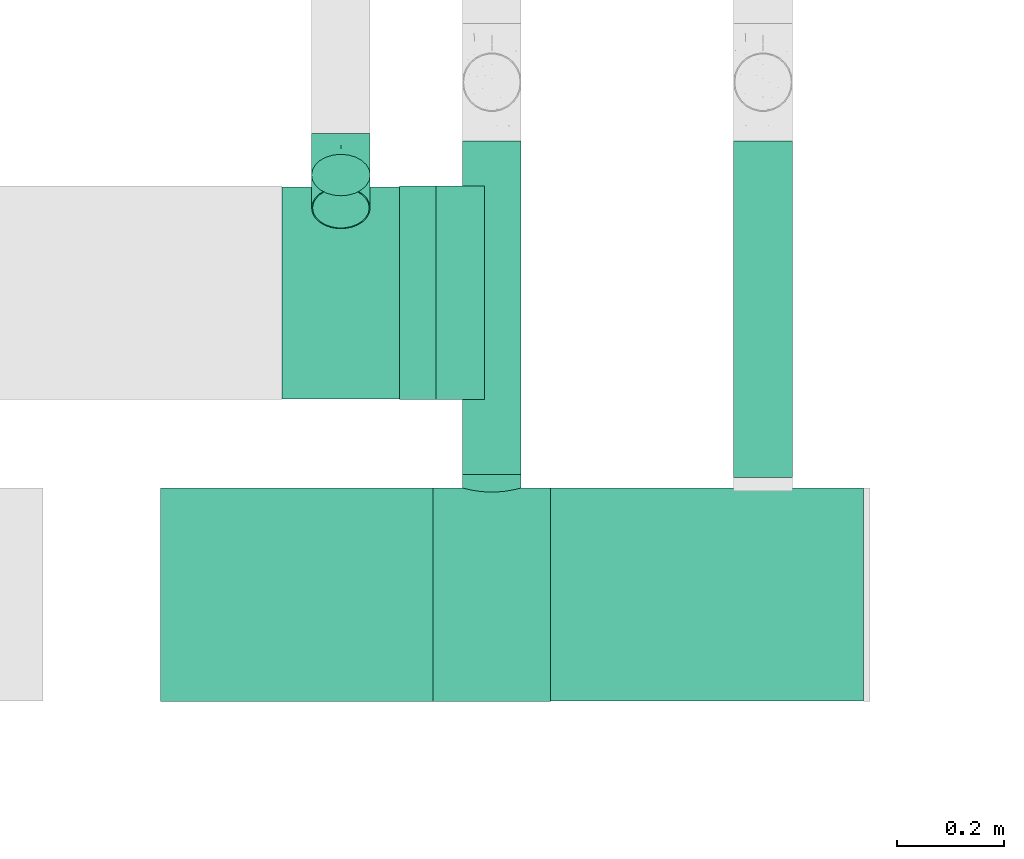
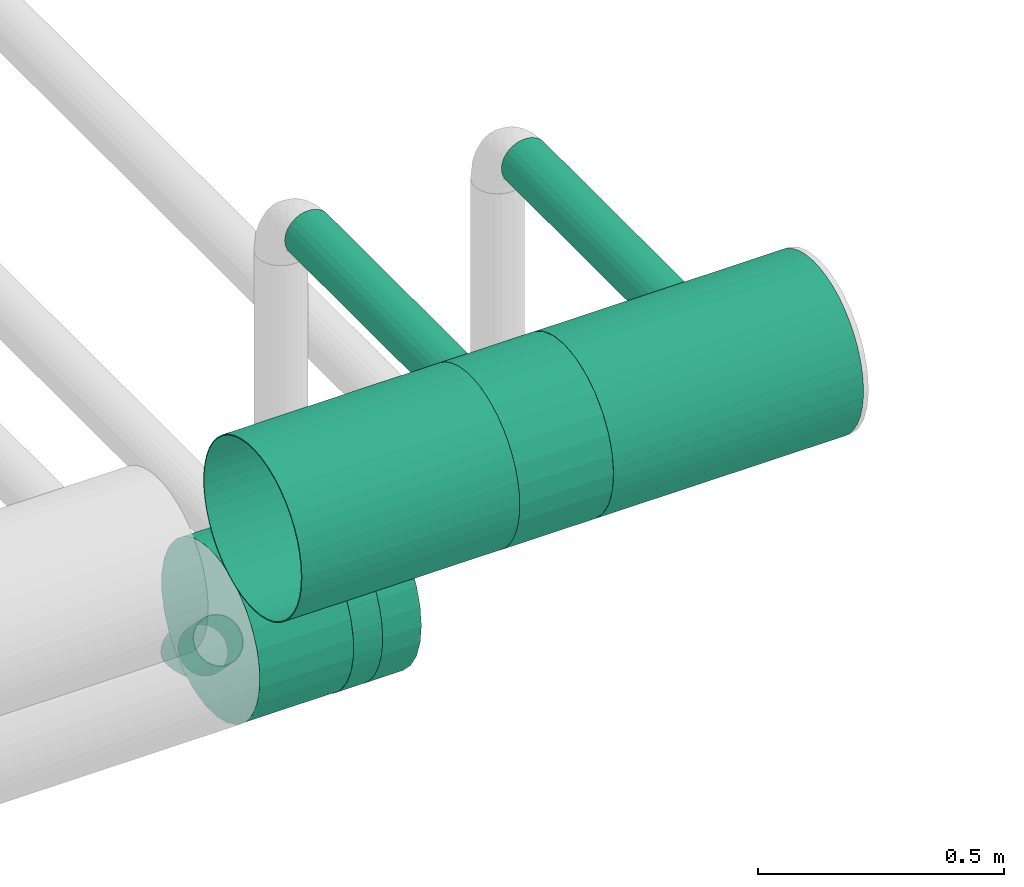
# One storey, part 71 of 91: 6 flow segments, 4 flow fittings.
"""IFC2X3 building model written with IfcOpenShell, lengths in millimetres."""

from ifc_helpers import new_model, entity, si_unit, converted_unit, derived_unit, direction, frame, origin_with_axes, origin_2d_with_axis, place, context, subcontext, project, spatial, hollow_circle, extrude, open_shell, surface_model, source, transform, mapped, material, layer, layer_set, layer_usage, type_object, element, save


model = new_model("IFC2X3")

# Units and contexts
model_context = context("Model", 3, precision=1e-05, world=origin_with_axes(), true_north=direction((0.0, 1.0)))
body_context = subcontext(model_context, "Body", "Model", "MODEL_VIEW")
ifc_project = project(units=[si_unit("AREAUNIT", "SQUARE_METRE"), si_unit("VOLUMEUNIT", "CUBIC_METRE", prefix="DECI"), si_unit("TIMEUNIT", "SECOND"), si_unit("THERMODYNAMICTEMPERATUREUNIT", "DEGREE_CELSIUS"), si_unit("PRESSUREUNIT", "PASCAL"), si_unit("MASSUNIT", "GRAM", prefix="KILO"), si_unit("LENGTHUNIT", "METRE", prefix="MILLI"), si_unit("POWERUNIT", "WATT"), si_unit("ELECTRICCURRENTUNIT", "AMPERE"), si_unit("ELECTRICVOLTAGEUNIT", "VOLT"), derived_unit("VOLUMETRICFLOWRATEUNIT", [(si_unit("VOLUMEUNIT", "CUBIC_METRE", prefix="DECI"), 1), (si_unit("TIMEUNIT", "SECOND"), -1)]), derived_unit("LINEARVELOCITYUNIT", [(si_unit("LENGTHUNIT", "METRE"), 1), (si_unit("TIMEUNIT", "SECOND"), -1)]), derived_unit("MASSDENSITYUNIT", [(si_unit("MASSUNIT", "GRAM", prefix="KILO"), 1), (si_unit("VOLUMEUNIT", "CUBIC_METRE"), -1)]), converted_unit("PLANEANGLEUNIT", "DEGREE", entity("IfcRatioMeasure", 0.01745), si_unit("PLANEANGLEUNIT", "RADIAN"), dimensions=[0, 0, 0, 0, 0, 0, 0])], contexts=[model_context])

# Site, building, storey
site_placement = place(None, origin_with_axes())
site = spatial("IfcSite", under=ifc_project, at=site_placement, CompositionType="ELEMENT")
building_placement = place(site_placement, origin_with_axes())
building = spatial("IfcBuilding", under=site, at=building_placement, Name="mc-building", CompositionType="ELEMENT")
storey_placement = place(building_placement, frame((0.0, 0.0, 8700.0), z_axis=(0.0, 0.0, 1.0), x_axis=(1.0, 0.0, 0.0)))
storey = spatial("IfcBuildingStorey", under=building, at=storey_placement, CompositionType="ELEMENT", Elevation=8700.0)

# Flow fittings
duct_fitting_type_1 = type_object("IfcDuctFittingType", PredefinedType="JUNCTION")
shared_shape_1 = source(origin_with_axes(), body_context, "Body", "SurfaceModel", [
    surface_model("IfcShellBasedSurfaceModel", [(0.0, -225.0, -55.0), (14.23505, -225.0, -53.12592), (-14.23505, -225.0, -53.12592), (-53.12592, -225.0, 14.23505), (-27.5, -225.0, -47.63139), (-47.63139, -225.0, -27.5), (-38.89087, -225.0, -38.89087), (55.0, -225.0, 0.0), (53.12592, -225.0, 14.23505), (38.89087, -225.0, -38.89087), (27.5, -225.0, -47.63139), (53.12592, -225.0, -14.23505), (47.63139, -225.0, -27.5), (-53.12592, -225.0, -14.23505), (-47.63139, -225.0, 27.5), (-38.89087, -225.0, 38.89087), (14.23505, -225.0, 53.12592), (-27.5, -225.0, 47.63139), (-14.23505, -225.0, 53.12592), (47.63139, -225.0, 27.5), (38.89087, -225.0, 38.89087), (27.5, -225.0, 47.63139), (0.0, -225.0, 55.0), (-55.0, -225.0, 0.0), (0.0, -192.28884, 55.0), (-12.29394, -192.68144, 53.60839), (-23.92751, -193.77184, 49.52246), (-34.31923, -195.32745, 42.97895), (-42.9874, -197.03532, 34.30865), (-49.52973, -198.56533, 23.91246), (-53.61252, -199.6229, 12.27592), (-55.0, -200.0, 0.0), (-49.52091, -198.56313, -23.93071), (-42.97449, -197.0325, -34.32482), (-53.60826, -199.62175, -12.29447), (-34.30293, -195.32458, -42.99196), (-23.90904, -193.76957, -49.53138), (-12.27509, -192.68024, -53.61271), (0.0, -192.28884, -55.0), (12.29394, -192.68144, -53.60839), (23.92751, -193.77184, -49.52246), (34.31923, -195.32745, -42.97895), (42.9874, -197.03532, -34.30865), (49.52973, -198.56533, -23.91246), (53.61252, -199.6229, -12.27592), (55.0, -200.0, 0.0), (49.52973, -198.56533, 23.91246), (42.9874, -197.03532, 34.30865), (53.61252, -199.6229, 12.27592), (34.31923, -195.32745, 42.97895), (23.92751, -193.77184, 49.52246), (12.29394, -192.68144, 53.60839), (-110.0, 0.0, -200.0), (-110.0, -44.50419, -194.98559), (-110.0, 44.50419, -194.98559), (-110.0, 194.98559, 44.50419), (-110.0, 86.77674, -180.19378), (-110.0, 180.19378, -86.77674), (-110.0, 156.36629, -124.69796), (-110.0, 124.69796, -156.36629), (-110.0, -200.0, 0.0), (-110.0, -194.98559, 44.50419), (-110.0, -124.69796, -156.36629), (-110.0, -86.77674, -180.19378), (-110.0, -156.36629, -124.69796), (-110.0, -180.19378, -86.77674), (-110.0, -194.98559, -44.50419), (-110.0, 194.98559, -44.50419), (-110.0, 180.19378, 86.77674), (-110.0, 156.36629, 124.69796), (-110.0, 86.77674, 180.19378), (-110.0, 124.69796, 156.36629), (-110.0, 44.50419, 194.98559), (-110.0, 0.0, 200.0), (-110.0, -156.36629, 124.69796), (-110.0, -180.19378, 86.77674), (-110.0, -86.77674, 180.19378), (-110.0, -44.50419, 194.98559), (-110.0, -124.69796, 156.36629), (-110.0, 200.0, 0.0), (110.0, 0.0, -200.0), (110.0, 44.50419, -194.98559), (110.0, 86.77674, -180.19378), (110.0, 200.0, 0.0), (110.0, 156.36629, -124.69796), (110.0, 180.19378, -86.77674), (110.0, 124.69796, -156.36629), (110.0, -156.36629, -124.69796), (110.0, -194.98559, 44.50419), (110.0, -86.77674, -180.19378), (110.0, -44.50419, -194.98559), (110.0, -124.69796, -156.36629), (110.0, -180.19378, -86.77674), (110.0, -194.98559, -44.50419), (110.0, -200.0, 0.0), (110.0, 194.98559, -44.50419), (110.0, 194.98559, 44.50419), (110.0, 180.19378, 86.77674), (110.0, 156.36629, 124.69796), (110.0, 124.69796, 156.36629), (110.0, 86.77674, 180.19378), (110.0, 44.50419, 194.98559), (110.0, -156.36629, 124.69796), (110.0, -180.19378, 86.77674), (110.0, -124.69796, 156.36629), (110.0, -86.77674, 180.19378), (110.0, -44.50419, 194.98559), (110.0, 0.0, 200.0), (-110.0, -197.4928, -22.25209), (110.0, -197.4928, -22.25209), (110.0, -197.4928, 22.25209), (-110.0, -197.4928, 22.25209)], [open_shell([[[0, 1, 2]], [[2, 3, 4]], [[5, 6, 3]], [[6, 4, 3]], [[2, 7, 8]], [[9, 7, 10]], [[1, 10, 7]], [[11, 7, 12]], [[9, 12, 7]], [[7, 2, 1]], [[5, 3, 13]], [[2, 14, 3]], [[2, 15, 14]], [[2, 16, 17]], [[17, 15, 2]], [[16, 18, 17]], [[2, 8, 19]], [[2, 19, 20]], [[2, 20, 21]], [[16, 2, 21]], [[16, 22, 18]], [[23, 13, 3]], [[22, 24, 25]], [[18, 25, 26]], [[22, 25, 18]], [[17, 27, 15]], [[17, 18, 26]], [[27, 17, 26]], [[28, 29, 14]], [[30, 31, 23]], [[29, 30, 3]], [[15, 28, 14]], [[3, 14, 29]], [[23, 3, 30]], [[28, 15, 27]], [[32, 33, 5]], [[34, 32, 13]], [[31, 34, 23]], [[23, 34, 13]], [[32, 5, 13]], [[33, 6, 5]], [[4, 35, 36]], [[36, 37, 2]], [[38, 0, 37]], [[4, 6, 35]], [[2, 4, 36]], [[37, 0, 2]], [[35, 6, 33]], [[0, 38, 39]], [[1, 39, 40]], [[0, 39, 1]], [[10, 41, 9]], [[10, 1, 40]], [[41, 10, 40]], [[42, 43, 12]], [[44, 45, 7]], [[43, 44, 11]], [[9, 42, 12]], [[11, 12, 43]], [[7, 11, 44]], [[42, 9, 41]], [[46, 47, 19]], [[48, 46, 8]], [[45, 48, 7]], [[7, 48, 8]], [[46, 19, 8]], [[47, 20, 19]], [[21, 49, 50]], [[50, 51, 16]], [[24, 22, 51]], [[20, 49, 21]], [[16, 21, 50]], [[22, 16, 51]], [[49, 20, 47]], [[52, 53, 54]], [[54, 55, 56]], [[55, 57, 58]], [[58, 59, 55]], [[59, 56, 55]], [[54, 60, 61]], [[62, 60, 63]], [[54, 53, 63]], [[60, 64, 65]], [[65, 66, 60]], [[60, 62, 64]], [[63, 60, 54]], [[55, 67, 57]], [[54, 68, 55]], [[54, 69, 68]], [[70, 71, 69]], [[70, 54, 72]], [[70, 69, 54]], [[72, 54, 73]], [[74, 73, 75]], [[54, 61, 75]], [[76, 77, 73]], [[73, 78, 76]], [[74, 78, 73]], [[54, 75, 73]], [[79, 67, 55]], [[80, 81, 82]], [[83, 80, 82]], [[84, 85, 83]], [[83, 86, 84]], [[83, 82, 86]], [[87, 80, 88]], [[80, 89, 90]], [[80, 91, 89]], [[91, 80, 87]], [[87, 88, 92]], [[93, 92, 88]], [[93, 88, 94]], [[85, 95, 83]], [[83, 96, 97]], [[98, 80, 97]], [[98, 99, 100]], [[80, 100, 101]], [[80, 98, 100]], [[80, 101, 102]], [[102, 103, 80]], [[88, 80, 103]], [[104, 102, 101]], [[104, 101, 105]], [[101, 106, 105]], [[101, 107, 106]], [[83, 97, 80]], [[72, 107, 101]], [[70, 101, 100]], [[71, 100, 99]], [[73, 107, 72]], [[72, 101, 70]], [[100, 71, 70]], [[99, 69, 71]], [[68, 98, 97]], [[55, 97, 96]], [[79, 96, 83]], [[69, 98, 68]], [[68, 97, 55]], [[96, 79, 55]], [[98, 69, 99]], [[83, 95, 79]], [[85, 84, 58]], [[95, 85, 67]], [[67, 79, 95]], [[58, 57, 85]], [[67, 85, 57]], [[84, 59, 58]], [[56, 86, 82]], [[54, 82, 81]], [[52, 81, 80]], [[59, 86, 56]], [[56, 82, 54]], [[81, 52, 54]], [[86, 59, 84]], [[90, 53, 80]], [[89, 63, 90]], [[65, 87, 92]], [[89, 91, 62]], [[87, 64, 91]], [[92, 40, 39]], [[39, 38, 92]], [[53, 90, 63]], [[62, 63, 89]], [[53, 52, 80]], [[38, 37, 65]], [[34, 108, 32]], [[64, 87, 65]], [[37, 36, 65]], [[64, 62, 91]], [[38, 65, 92]], [[42, 109, 43]], [[93, 42, 41]], [[93, 109, 42]], [[41, 40, 93]], [[93, 40, 92]], [[94, 45, 44]], [[43, 109, 44]], [[44, 109, 94]], [[36, 35, 66]], [[33, 32, 108]], [[33, 66, 35]], [[36, 66, 65]], [[34, 60, 108]], [[31, 60, 34]], [[108, 66, 33]], [[45, 94, 48]], [[94, 110, 48]], [[110, 47, 46]], [[47, 110, 88]], [[49, 47, 88]], [[29, 111, 30]], [[60, 31, 30]], [[111, 60, 30]], [[27, 26, 61]], [[61, 111, 28]], [[61, 28, 27]], [[26, 75, 61]], [[49, 88, 50]], [[51, 103, 24]], [[48, 110, 46]], [[51, 50, 103]], [[74, 103, 102]], [[103, 50, 88]], [[105, 106, 77]], [[76, 104, 105]], [[78, 102, 104]], [[73, 106, 107]], [[25, 24, 75]], [[28, 111, 29]], [[75, 24, 103]], [[74, 75, 103]], [[25, 75, 26]], [[102, 78, 74]], [[104, 76, 78]], [[77, 76, 105]], [[106, 73, 77]]])]),
])
for number, where, z_axis, x_axis in (
    (1, (26120.56538, 10645.73579, 668.0), (0.0, 0.707107, 0.707107), (-1.0, 0.0, 0.0)),
    (2, (26403.5823, 10080.05037, 1344.0), (0.0, 0.0, 1.0), (-1.0, 0.0, 0.0)),
):
    element("IfcFlowFitting", number, at=place(storey_placement, frame(where, z_axis=z_axis, x_axis=x_axis)), inside=storey, type_object=duct_fitting_type_1, context=body_context, shape_type="MappedRepresentation", body=[
        mapped(shared_shape_1, transform((0.0, 0.0, 0.0), scale=1.0)),
    ])
duct_fitting_type_2 = type_object("IfcDuctFittingType", Name="BU", PredefinedType="BEND")
shared_shape_2 = source(origin_with_axes(), body_context, "Body", "SurfaceModel", [
    surface_model("IfcShellBasedSurfaceModel", [(-45.56349, 0.0, -55.0), (-45.56349, -14.23505, -53.12592), (-45.56349, 14.23505, -53.12592), (-45.56349, 53.12592, 14.23505), (-45.56349, 27.5, -47.63139), (-45.56349, 38.89087, -38.89087), (-45.56349, 47.63139, -27.5), (-45.56349, -55.0, 0.0), (-45.56349, -53.12592, 14.23505), (-45.56349, -38.89087, -38.89087), (-45.56349, -27.5, -47.63139), (-45.56349, -53.12592, -14.23505), (-45.56349, -47.63139, -27.5), (-45.56349, 53.12592, -14.23505), (-45.56349, 47.63139, 27.5), (-45.56349, 38.89087, 38.89087), (-45.56349, -14.23505, 53.12592), (-45.56349, 27.5, 47.63139), (-45.56349, 14.23505, 53.12592), (-45.56349, -47.63139, 27.5), (-45.56349, -38.89087, 38.89087), (-45.56349, -27.5, 47.63139), (-45.56349, 0.0, 55.0), (-45.56349, 55.0, 0.0), (22.15256, 42.28395, -53.12592), (-6.67262, 71.10913, 0.0), (32.21826, 32.21826, -55.0), (12.77282, 51.66369, -47.63139), (-1.46223, 65.89874, -27.5), (4.71825, 59.71825, -38.89087), (59.71825, 4.71825, -38.89087), (69.78395, -5.34744, 14.23505), (51.66369, 12.77282, -47.63139), (42.28395, 22.15256, -53.12592), (65.89874, -1.46223, -27.5), (69.78395, -5.34744, -14.23505), (71.10913, -6.67262, 0.0), (-5.34744, 69.78395, -14.23505), (-5.34744, 69.78395, 14.23505), (-1.46223, 65.89874, 27.5), (4.71825, 59.71825, 38.89087), (32.21826, 32.21826, 55.0), (12.77282, 51.66369, 47.63139), (22.15256, 42.28395, 53.12592), (59.71825, 4.71825, 38.89087), (65.89874, -1.46223, 27.5), (42.28395, 22.15256, 53.12592), (51.66369, 12.77282, 47.63139), (-20.16649, 48.68621, 33.48188), (-26.97111, 35.77503, 43.63444), (-7.30443, 43.73336, 43.63444), (-17.0934, 3.74816, 55.0), (-18.00408, 15.44793, 53.78143), (-30.11707, 22.39897, 50.81337), (-7.49776, 55.63651, 33.48188), (-15.97018, 58.74288, 21.04759), (-31.18231, 52.58712, 21.04759), (-18.35174, 61.03934, 10.51509), (-28.67677, 56.60048, 10.47121), (-34.03924, 44.64267, 33.48188), (-11.52288, 27.81868, 50.81338), (1.19951, 23.16465, 53.81115), (-33.77926, 57.34403, 0.0), (5.4586, 37.12132, 50.81809), (-24.5159, 59.18663, 0.0), (-16.66281, 64.4339, 0.0), (9.43651, 14.73721, 55.0), (-6.22531, 44.36822, -43.63444), (5.4586, 37.12132, -50.81809), (-34.03924, 44.64267, -33.48188), (9.43651, 14.73721, -55.0), (-17.0934, 3.74816, -55.0), (1.19951, 23.16465, -53.81115), (-11.52288, 27.81868, -50.81338), (-30.11707, 22.39897, -50.81337), (-25.75914, 36.08917, -43.63444), (-30.24487, 52.83011, -21.04759), (-20.16649, 48.68621, -33.48188), (-7.49776, 55.63651, -33.48188), (-18.00408, 15.44793, -53.78143), (-28.68366, 56.62226, -10.35271), (-14.15883, 63.53074, -10.87592), (-15.13548, 59.23394, -21.04759), (3.19797, -7.72059, -52.16847), (3.1272, -18.04126, -47.9241), (13.63233, -32.91136, -32.06475), (45.23618, -22.99734, -20.4997), (16.67434, -40.25541, -15.9539), (-17.3935, -51.68264, -9.80849), (-2.85835, -49.37776, 0.0), (48.84421, -24.24609, -9.80849), (-16.38424, -42.76862, -30.85433), (-6.97383, -29.41689, -42.70541), (41.82739, -18.65658, -30.85433), (-15.72523, -48.24839, -20.4997), (29.28945, -13.63928, -42.80781), (26.81493, -3.56603, -49.15704), (36.93651, -32.89419, 0.0), (-15.72523, -48.24839, 20.4997), (-17.3935, -51.68264, 9.80849), (-16.38424, -42.76862, 30.85433), (16.67434, -40.25541, 15.9539), (3.19797, -7.72059, 52.16847), (10.54583, -14.96836, 47.9241), (13.63233, -32.91136, 32.06475), (45.23618, -22.99734, 20.4997), (41.82739, -18.65658, 30.85433), (-11.06635, -30.3552, 42.80781), (25.73213, -15.86964, 42.70541), (-16.43945, -21.48258, 49.15704), (48.84421, -24.24609, 9.80849)], [open_shell([[[0, 1, 2]], [[2, 3, 4]], [[5, 3, 6]], [[4, 3, 5]], [[2, 7, 8]], [[9, 7, 10]], [[1, 10, 7]], [[11, 7, 12]], [[9, 12, 7]], [[7, 2, 1]], [[13, 6, 3]], [[14, 3, 2]], [[15, 14, 2]], [[16, 17, 2]], [[2, 17, 15]], [[16, 18, 17]], [[19, 20, 2]], [[19, 2, 8]], [[20, 21, 2]], [[2, 21, 16]], [[16, 22, 18]], [[23, 13, 3]], [[24, 25, 26]], [[27, 25, 24]], [[28, 25, 29]], [[29, 25, 27]], [[30, 26, 31]], [[26, 30, 32]], [[32, 33, 26]], [[34, 31, 35]], [[31, 34, 30]], [[35, 31, 36]], [[37, 25, 28]], [[26, 38, 39]], [[26, 39, 40]], [[41, 40, 42]], [[26, 40, 41]], [[42, 43, 41]], [[26, 44, 45]], [[31, 26, 45]], [[46, 47, 26]], [[47, 44, 26]], [[46, 26, 41]], [[26, 25, 38]], [[48, 49, 50]], [[22, 51, 52]], [[17, 49, 15]], [[53, 17, 18]], [[49, 17, 53]], [[54, 50, 40]], [[48, 55, 56]], [[55, 57, 58]], [[59, 14, 15]], [[60, 53, 52]], [[50, 49, 60]], [[58, 3, 56]], [[52, 51, 61]], [[62, 23, 3]], [[63, 50, 60]], [[50, 42, 40]], [[3, 58, 62]], [[43, 61, 41]], [[62, 58, 64]], [[48, 59, 49]], [[14, 56, 3]], [[40, 39, 54]], [[57, 64, 58]], [[39, 38, 55]], [[63, 60, 61]], [[54, 55, 48]], [[65, 57, 38]], [[56, 14, 59]], [[38, 25, 65]], [[60, 52, 61]], [[49, 59, 15]], [[55, 58, 56]], [[56, 59, 48]], [[55, 54, 39]], [[50, 54, 48]], [[18, 22, 52]], [[49, 53, 60]], [[18, 52, 53]], [[61, 51, 66]], [[41, 61, 66]], [[63, 61, 43]], [[43, 42, 63]], [[50, 63, 42]], [[38, 57, 55]], [[64, 57, 65]], [[67, 27, 68]], [[69, 5, 6]], [[70, 71, 72]], [[73, 74, 75]], [[76, 77, 69]], [[29, 78, 28]], [[2, 79, 0]], [[13, 23, 62]], [[2, 74, 79]], [[5, 75, 4]], [[77, 78, 67]], [[13, 62, 80]], [[64, 80, 62]], [[81, 80, 64]], [[67, 73, 75]], [[82, 77, 76]], [[81, 64, 65]], [[76, 69, 6]], [[82, 76, 80]], [[24, 72, 68]], [[74, 2, 4]], [[27, 67, 29]], [[26, 70, 72]], [[69, 75, 5]], [[82, 28, 78]], [[72, 71, 79]], [[6, 13, 76]], [[77, 67, 75]], [[13, 80, 76]], [[82, 37, 28]], [[81, 25, 37]], [[82, 81, 37]], [[75, 69, 77]], [[67, 78, 29]], [[82, 78, 77]], [[75, 74, 4]], [[79, 74, 73]], [[79, 73, 72]], [[79, 71, 0]], [[68, 72, 73]], [[26, 72, 24]], [[67, 68, 73]], [[27, 24, 68]], [[80, 81, 82]], [[25, 81, 65]], [[1, 83, 84]], [[85, 86, 87]], [[0, 71, 1]], [[88, 87, 89]], [[90, 86, 35]], [[91, 92, 85]], [[11, 88, 7]], [[30, 34, 93]], [[11, 12, 94]], [[92, 91, 9]], [[85, 94, 91]], [[94, 85, 87]], [[95, 93, 85]], [[85, 92, 95]], [[83, 71, 70]], [[12, 9, 91]], [[70, 26, 33]], [[96, 84, 83]], [[1, 71, 83]], [[95, 96, 32]], [[95, 30, 93]], [[95, 32, 30]], [[97, 89, 87]], [[34, 86, 93]], [[36, 97, 90]], [[94, 88, 11]], [[34, 35, 86]], [[90, 87, 86]], [[93, 86, 85]], [[32, 96, 33]], [[84, 10, 1]], [[33, 83, 70]], [[94, 12, 91]], [[10, 92, 9]], [[87, 88, 94]], [[7, 88, 89]], [[36, 90, 35]], [[87, 90, 97]], [[84, 95, 92]], [[33, 96, 83]], [[95, 84, 96]], [[10, 84, 92]], [[8, 98, 19]], [[7, 89, 99]], [[19, 98, 100]], [[101, 98, 99]], [[46, 102, 103]], [[104, 105, 106]], [[100, 98, 104]], [[107, 104, 108]], [[16, 51, 22]], [[51, 16, 102]], [[107, 20, 100]], [[107, 109, 21]], [[21, 20, 107]], [[103, 47, 46]], [[101, 89, 97]], [[105, 110, 31]], [[44, 47, 108]], [[105, 104, 101]], [[107, 100, 104]], [[31, 110, 36]], [[109, 16, 21]], [[108, 106, 44]], [[105, 45, 106]], [[41, 66, 46]], [[102, 66, 51]], [[46, 66, 102]], [[104, 98, 101]], [[99, 98, 8]], [[106, 108, 104]], [[110, 101, 97]], [[45, 44, 106]], [[105, 31, 45]], [[20, 19, 100]], [[109, 103, 102]], [[101, 110, 105]], [[36, 110, 97]], [[7, 99, 8]], [[101, 99, 89]], [[103, 107, 108]], [[16, 109, 102]], [[107, 103, 109]], [[47, 103, 108]]])]),
])
flow_fitting_1_placement = place(storey_placement, frame((26120.56538, 10898.73579, 415.0), z_axis=(-1.0, 0.0, 0.0), x_axis=(0.0, -1.0, 0.0)))
element("IfcFlowFitting", 3, at=flow_fitting_1_placement, inside=storey, type_object=duct_fitting_type_2, Name="BU", context=body_context, shape_type="MappedRepresentation", body=[
    mapped(shared_shape_2, transform((0.0, 0.0, 0.0), scale=1.0)),
])
duct_fitting_type_3 = type_object("IfcDuctFittingType", Name="EPF", PredefinedType="OBSTRUCTION")
shared_shape_3 = source(origin_with_axes(), body_context, "Body", "SurfaceModel", [
    surface_model("IfcShellBasedSurfaceModel", [(0.0, 86.77674, -180.19378), (0.0, 44.50419, -194.98559), (0.0, 0.0, -200.0), (0.0, 124.69796, -156.36629), (0.0, 180.19378, -86.77674), (0.0, 194.98559, -44.50419), (0.0, 156.36629, -124.69796), (0.0, 0.0, 200.0), (0.0, -194.98559, -44.50419), (0.0, -86.77674, -180.19378), (0.0, -124.69796, -156.36629), (0.0, -44.50419, -194.98559), (0.0, -180.19378, -86.77674), (0.0, -156.36629, -124.69796), (0.0, -200.0, 0.0), (0.0, -194.98559, 44.50419), (0.0, 200.0, 0.0), (0.0, 180.19378, 86.77674), (0.0, 194.98559, 44.50419), (0.0, 156.36629, 124.69796), (0.0, 86.77674, 180.19378), (0.0, 124.69796, 156.36629), (0.0, 44.50419, 194.98559), (0.0, -180.19378, 86.77674), (0.0, -156.36629, 124.69796), (0.0, -86.77674, 180.19378), (0.0, -44.50419, 194.98559), (0.0, -124.69796, 156.36629), (91.0, 44.50419, -194.98559), (91.0, -44.50419, -194.98559), (91.0, 0.0, -200.0), (91.0, 86.77674, -180.19378), (91.0, 156.36629, -124.69796), (91.0, 180.19378, -86.77674), (91.0, 124.69796, -156.36629), (91.0, 194.98559, -44.50419), (91.0, -124.69796, -156.36629), (91.0, -86.77674, -180.19378), (91.0, -194.98559, -44.50419), (91.0, -156.36629, -124.69796), (91.0, -180.19378, -86.77674), (91.0, -200.0, 0.0), (91.0, 44.50419, 194.98559), (91.0, 86.77674, 180.19378), (91.0, 194.98559, 44.50419), (91.0, 180.19378, 86.77674), (91.0, 156.36629, 124.69796), (91.0, 124.69796, 156.36629), (91.0, -44.50419, 194.98559), (91.0, -180.19378, 86.77674), (91.0, -194.98559, 44.50419), (91.0, -156.36629, 124.69796), (91.0, -124.69796, 156.36629), (91.0, -86.77674, 180.19378), (91.0, 0.0, 200.0), (91.0, 200.0, 0.0)], [open_shell([[[0, 1, 2]], [[3, 0, 2]], [[4, 2, 5]], [[6, 2, 4]], [[6, 3, 2]], [[7, 2, 8]], [[9, 10, 11]], [[8, 11, 10]], [[12, 10, 13]], [[8, 10, 12]], [[11, 8, 2]], [[14, 15, 8]], [[5, 2, 16]], [[17, 18, 16]], [[19, 17, 16]], [[16, 20, 21]], [[22, 20, 2]], [[21, 19, 16]], [[2, 7, 22]], [[23, 24, 8]], [[8, 15, 23]], [[25, 26, 7]], [[25, 8, 27]], [[8, 24, 27]], [[8, 25, 7]], [[2, 20, 16]], [[28, 29, 30]], [[31, 29, 28]], [[32, 33, 29]], [[32, 29, 34]], [[29, 31, 34]], [[29, 33, 35]], [[29, 36, 37]], [[36, 29, 38]], [[39, 36, 40]], [[38, 40, 36]], [[41, 38, 29]], [[41, 29, 42]], [[29, 35, 43]], [[44, 45, 35]], [[35, 45, 46]], [[47, 43, 35]], [[42, 29, 43]], [[46, 47, 35]], [[48, 41, 42]], [[41, 49, 50]], [[51, 49, 41]], [[41, 52, 51]], [[41, 53, 52]], [[53, 41, 48]], [[42, 54, 48]], [[55, 44, 35]], [[7, 54, 42]], [[43, 47, 20]], [[20, 42, 43]], [[7, 42, 22]], [[21, 20, 47]], [[42, 20, 22]], [[47, 19, 21]], [[17, 46, 45]], [[18, 45, 44]], [[16, 44, 55]], [[19, 46, 17]], [[17, 45, 18]], [[44, 16, 18]], [[46, 19, 47]], [[16, 55, 35]], [[35, 33, 5]], [[32, 4, 33]], [[16, 35, 5]], [[4, 5, 33]], [[6, 4, 32]], [[32, 34, 6]], [[0, 34, 31]], [[1, 31, 28]], [[2, 28, 30]], [[3, 34, 0]], [[0, 31, 1]], [[28, 2, 1]], [[34, 3, 6]], [[2, 30, 29]], [[11, 29, 37]], [[10, 37, 36]], [[2, 29, 11]], [[9, 11, 37]], [[10, 9, 37]], [[36, 39, 10]], [[12, 39, 40]], [[8, 40, 38]], [[14, 38, 41]], [[13, 39, 12]], [[12, 40, 8]], [[38, 14, 8]], [[39, 13, 10]], [[14, 41, 50]], [[49, 51, 24]], [[15, 50, 49]], [[14, 50, 15]], [[24, 23, 49]], [[49, 23, 15]], [[51, 27, 24]], [[25, 52, 53]], [[26, 53, 48]], [[7, 48, 54]], [[27, 52, 25]], [[25, 53, 26]], [[48, 7, 26]], [[52, 27, 51]]])]),
])
flow_fitting_2_placement = place(storey_placement, frame((26298.56367, 10645.73579, 668.0), z_axis=(0.0, 0.0, 1.0), x_axis=(1.0, 0.0, 0.0)))
element("IfcFlowFitting", 4, at=flow_fitting_2_placement, inside=storey, type_object=duct_fitting_type_3, context=body_context, shape_type="MappedRepresentation", body=[
    mapped(shared_shape_3, transform((0.0, 0.0, 0.0), scale=1.0)),
])

# Flow segments
ifc_material = material(Name="FZ1")
ifc_layer = layer(ifc_material, 0.0)
ifc_layer_set = layer_set([ifc_layer], Name="FZ1")
ifc_layer_usage = layer_usage(ifc_layer_set, "AXIS1", "POSITIVE", 0.0)
duct_segment_type_1 = type_object("IfcDuctSegmentType", PredefinedType="RIGIDSEGMENT")
shared_shape_4 = source(origin_with_axes(), body_context, "Body", "SweptSolid", [
    extrude(hollow_circle(Radius=55.0, WallThickness=2.0, at=origin_2d_with_axis()), frame((0.0, 0.0, 0.0), z_axis=(1.0, 0.0, 0.0), x_axis=(0.0, 1.0, 0.0)), (0.0, 0.0, 1.0), 87.2),
])
flow_segment_1_placement = place(storey_placement, frame((26120.56538, 10804.83482, 508.90097), z_axis=(0.0, -0.707107, -0.707107), x_axis=(0.0, 0.707107, -0.707107)))
element("IfcFlowSegment", 5, at=flow_segment_1_placement, inside=storey, type_object=duct_segment_type_1, material=ifc_layer_usage, context=body_context, shape_type="MappedRepresentation", body=[
    mapped(shared_shape_4, transform((0.0, 0.0, 0.0), scale=1.0)),
])
duct_segment_type_2 = type_object("IfcDuctSegmentType", Name="Safe", PredefinedType="RIGIDSEGMENT")
shared_shape_5 = source(origin_with_axes(), body_context, "Body", "SweptSolid", [
    extrude(hollow_circle(Radius=200.0, WallThickness=2.0, at=origin_2d_with_axis()), frame((0.0, 0.0, 0.0), z_axis=(1.0, 0.0, 0.0), x_axis=(0.0, 1.0, 0.0)), (0.0, 0.0, 1.0), 68.0),
])
flow_segment_2_placement = place(storey_placement, frame((26230.56538, 10645.73579, 668.0), z_axis=(0.0, 0.707107, -0.707107), x_axis=(1.0, 0.0, 0.0)))
element("IfcFlowSegment", 6, at=flow_segment_2_placement, inside=storey, type_object=duct_segment_type_2, material=ifc_layer_usage, Name="Safe", context=body_context, shape_type="MappedRepresentation", body=[
    mapped(shared_shape_5, transform((0.0, 0.0, 0.0), scale=1.0)),
])
shared_shape_6 = source(origin_with_axes(), body_context, "Body", "SweptSolid", [
    extrude(hollow_circle(Radius=55.0, WallThickness=2.0, at=origin_2d_with_axis()), frame((0.0, 0.0, 0.0), z_axis=(1.0, 0.0, 0.0), x_axis=(0.0, 1.0, 0.0)), (0.0, 0.0, 1.0), 625.5),
])
flow_segment_3_placement = place(storey_placement, frame((26403.5823, 10305.05037, 1344.0), z_axis=(0.0, 0.0, 1.0), x_axis=(0.0, 1.0, 0.0)))
element("IfcFlowSegment", 7, at=flow_segment_3_placement, inside=storey, type_object=duct_segment_type_1, material=ifc_layer_usage, context=body_context, shape_type="MappedRepresentation", body=[
    mapped(shared_shape_6, transform((0.0, 0.0, 0.0), scale=1.0)),
])
shared_shape_7 = source(origin_with_axes(), body_context, "Body", "SweptSolid", [
    extrude(hollow_circle(Radius=200.0, WallThickness=2.0, at=origin_2d_with_axis()), frame((0.0, 0.0, 0.0), z_axis=(1.0, 0.0, 0.0), x_axis=(0.0, 1.0, 0.0)), (0.0, 0.0, 1.0), 511.0),
])
flow_segment_4_placement = place(storey_placement, frame((26293.5823, 10080.05037, 1344.0), z_axis=(0.0, 0.0, 1.0), x_axis=(-1.0, 0.0, 0.0)))
element("IfcFlowSegment", 8, at=flow_segment_4_placement, inside=storey, type_object=duct_segment_type_2, material=ifc_layer_usage, Name="Safe", context=body_context, shape_type="MappedRepresentation", body=[
    mapped(shared_shape_7, transform((0.0, 0.0, 0.0), scale=1.0)),
])
shared_shape_8 = source(origin_with_axes(), body_context, "Body", "SweptSolid", [
    extrude(hollow_circle(Radius=55.0, WallThickness=2.0, at=origin_2d_with_axis()), frame((0.0, 0.0, 0.0), z_axis=(1.0, 0.0, 0.0), x_axis=(0.0, 1.0, 0.0)), (0.0, 0.0, 1.0), 630.5),
])
flow_segment_5_placement = place(storey_placement, frame((26911.82755, 10300.05037, 1344.0), z_axis=(0.0, 0.0, 1.0), x_axis=(0.0, 1.0, 0.0)))
element("IfcFlowSegment", 9, at=flow_segment_5_placement, inside=storey, type_object=duct_segment_type_1, material=ifc_layer_usage, context=body_context, shape_type="MappedRepresentation", body=[
    mapped(shared_shape_8, transform((0.0, 0.0, 0.0), scale=1.0)),
])
shared_shape_9 = source(origin_with_axes(), body_context, "Body", "SweptSolid", [
    extrude(hollow_circle(Radius=200.0, WallThickness=2.0, at=origin_2d_with_axis()), frame((0.0, 0.0, 0.0), z_axis=(1.0, 0.0, 0.0), x_axis=(0.0, 1.0, 0.0)), (0.0, 0.0, 1.0), 586.4),
])
flow_segment_6_placement = place(storey_placement, frame((26513.5823, 10080.05037, 1344.0), z_axis=(0.0, 0.0, 1.0), x_axis=(1.0, 0.0, 0.0)))
element("IfcFlowSegment", 10, at=flow_segment_6_placement, inside=storey, type_object=duct_segment_type_2, material=ifc_layer_usage, Name="Safe", context=body_context, shape_type="MappedRepresentation", body=[
    mapped(shared_shape_9, transform((0.0, 0.0, 0.0), scale=1.0)),
])

save(model, "model.ifc")
